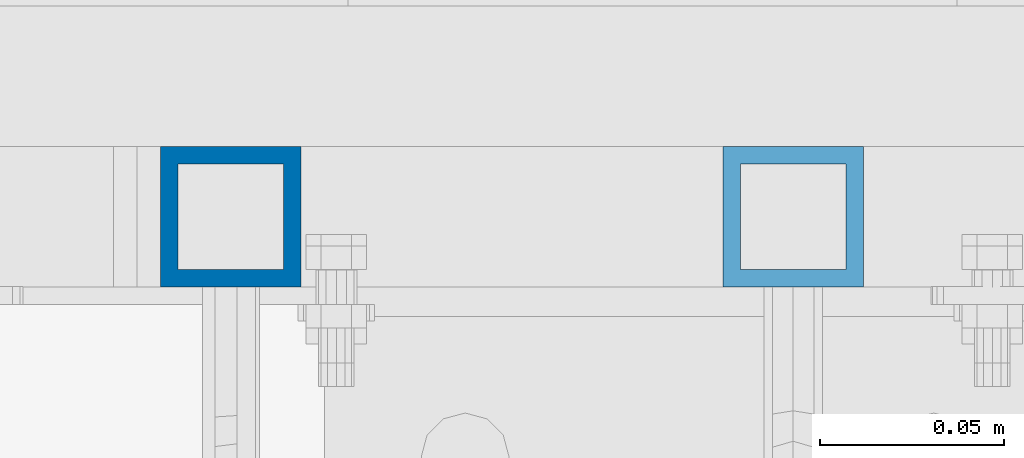
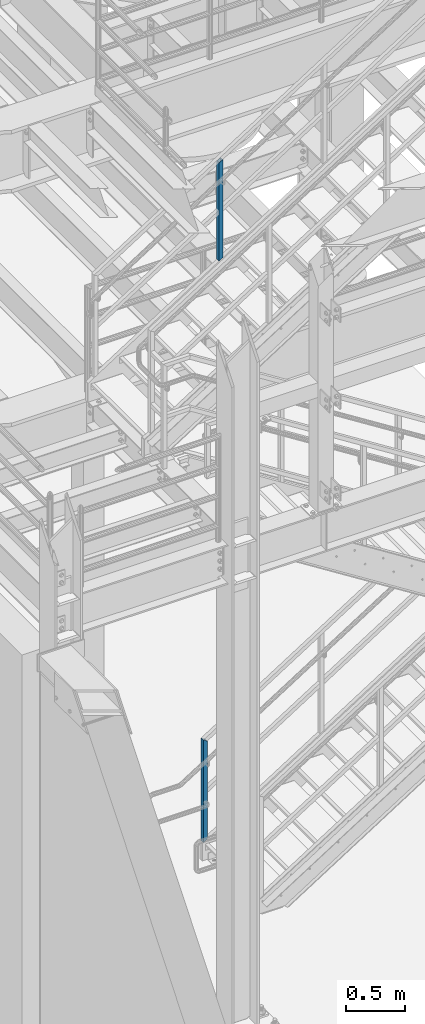
# One storey, part 616 of 1876: 2 columns, 2 elements without a shape of their own.
"""IFC2X3 building model written with IfcOpenShell, lengths in millimetres."""

from ifc_helpers import new_model, si_unit, frame, origin_with_axes, place, context, subcontext, project, spatial, faceted_brep, material, type_object, element, aggregate, save


model = new_model("IFC2X3")

# Units and contexts
model_context = context("Model", 3, precision=1e-05, world=origin_with_axes())
body_context = subcontext(model_context, "Body", "Model", "MODEL_VIEW")
ifc_project = project(units=[si_unit("LENGTHUNIT", "METRE", prefix="MILLI"), si_unit("AREAUNIT", "SQUARE_METRE"), si_unit("VOLUMEUNIT", "CUBIC_METRE"), si_unit("MASSUNIT", "GRAM", prefix="KILO"), si_unit("TIMEUNIT", "SECOND"), si_unit("PLANEANGLEUNIT", "RADIAN"), si_unit("SOLIDANGLEUNIT", "STERADIAN"), si_unit("THERMODYNAMICTEMPERATUREUNIT", "DEGREE_CELSIUS"), si_unit("LUMINOUSINTENSITYUNIT", "LUMEN")], contexts=[model_context])

# Site, building, storey
site_placement = place(None, origin_with_axes())
site = spatial("IfcSite", under=ifc_project, at=site_placement, CompositionType="ELEMENT")
building_placement = place(site_placement, origin_with_axes())
building = spatial("IfcBuilding", under=site, at=building_placement, Name="Undefined", CompositionType="ELEMENT")
storey_placement = place(building_placement, origin_with_axes())
storey = spatial("IfcBuildingStorey", under=building, at=storey_placement, Name="Undefined", CompositionType="ELEMENT", Elevation=0.0)

# Assembly, column
assembly_1_placement = place(storey_placement, origin_with_axes())
assembly_1 = element("IfcElementAssembly", 1, at=assembly_1_placement, inside=storey, Name="RAIL", AssemblyPlace="NOTDEFINED", PredefinedType="RIGID_FRAME")
ifc_material = material()
column_type = type_object("IfcColumnType", Name="HSS1-1/2X1-1/2X3/16", PredefinedType="NOTDEFINED")
column_1_placement = place(assembly_1_placement, frame((2743.20000001393, -4781.55000114554, 207.332759761854), z_axis=(-1.0, 0.0, 0.0), x_axis=(0.0, 0.0, 1.0)))
column_1 = element("IfcColumn", 2, at=column_1_placement, type_object=column_type, material=ifc_material, Name="POST", ObjectType="HSS1-1/2X1-1/2X3/16", context=body_context, shape_type="Brep", body=[
    faceted_brep([(9.06405233918804, 14.2874994260001, -14.2874994260001), (9.06405233918804, -14.2874994260001, -14.2874994260001), (1028.86378150912, -14.2874994260001, -14.2874994260001), (1028.86378150912, 14.2874994260001, -14.2874994260001), (-9.06405233919031, -14.2874994260001, 14.2874994260001), (1044.57587095721, -14.2874994260001, 14.2874994260001), (-9.06405233919031, 14.2874994260001, 14.2874994260001), (1044.57587095721, 14.2874994260001, 14.2874994260001), (12.0854031191295, 19.0499992349996, -19.0499992349996), (-12.0854031191318, 19.0499992349996, 19.0499992349996), (1047.19455253207, 19.0499992349996, 19.0499992350001), (1026.24509902744, 19.0499992349996, -19.0499992349996), (-12.0854031191318, -19.0499992349996, 19.0499992349996), (1047.19455253207, -19.0499992349996, 19.0499992350001), (12.0854031191295, -19.0499992349996, -19.0499992349996), (1026.24509902744, -19.0500000000002, -19.0499992349996)], [[[0, 1, 2, 3]], [[1, 4, 5, 2]], [[4, 6, 7, 5]], [[6, 0, 3, 7]], [[8, 9, 10, 11]], [[9, 12, 13, 10]], [[12, 14, 15, 13]], [[14, 8, 11, 15]], [[13, 15, 11, 10], [5, 7, 3, 2]], [[14, 12, 9, 8], [6, 4, 1, 0]]]),
])
aggregate(assembly_1, [column_1])

assembly_2_placement = place(storey_placement, origin_with_axes())
assembly_2 = element("IfcElementAssembly", 3, at=assembly_2_placement, inside=storey, Name="RAIL", AssemblyPlace="NOTDEFINED", PredefinedType="RIGID_FRAME")
column_2_placement = place(assembly_2_placement, frame((2895.60000031138, -4781.55000114554, 6156.41367959304), z_axis=(-1.0, 0.0, 0.0), x_axis=(0.0, 0.0, 1.0)))
column_2 = element("IfcColumn", 4, at=column_2_placement, type_object=column_type, material=ifc_material, Name="POST", ObjectType="HSS1-1/2X1-1/2X3/16", context=body_context, shape_type="Brep", body=[
    faceted_brep([(1026.23571825648, -19.0500000000002, -19.0499992349996), (1026.23571825648, 19.0499992349996, -19.0499992349996), (1001.99026470106, 19.0499992349996, 19.0499992349996), (1001.99026470106, -19.0499992349996, 19.0499992349996), (1023.20503656197, -14.2874994260001, -14.2874994260001), (1005.02094639574, -14.2874994260001, 14.2874994260001), (1005.02094639574, 14.2874994260001, 14.2874994260001), (1023.20503656197, 14.2874994260001, -14.2874994260001), (-12.1227267776903, 19.0499992349996, 19.0499992349996), (-12.1227267776903, -19.0499992349996, 19.0499992349996), (12.1227267777067, -19.0499992349996, -19.0499992349996), (12.1227267777067, 19.0499992349996, -19.0499992349996), (-9.09204508310631, 14.2874994260001, 14.2874994260001), (-9.09204508310631, -14.2874994260001, 14.2874994260001), (9.09204508312268, -14.2874994260001, -14.2874994260001), (9.09204508312268, 14.2874994260001, -14.2874994260001)], [[[0, 1, 2, 3], [4, 5, 6, 7]], [[8, 9, 3, 2]], [[9, 10, 0, 3]], [[10, 11, 1, 0]], [[11, 8, 2, 1]], [[10, 9, 8, 11], [12, 13, 14, 15]], [[15, 14, 4, 7]], [[12, 15, 7, 6]], [[13, 12, 6, 5]], [[14, 13, 5, 4]]]),
])
aggregate(assembly_2, [column_2])

save(model, "model.ifc")
